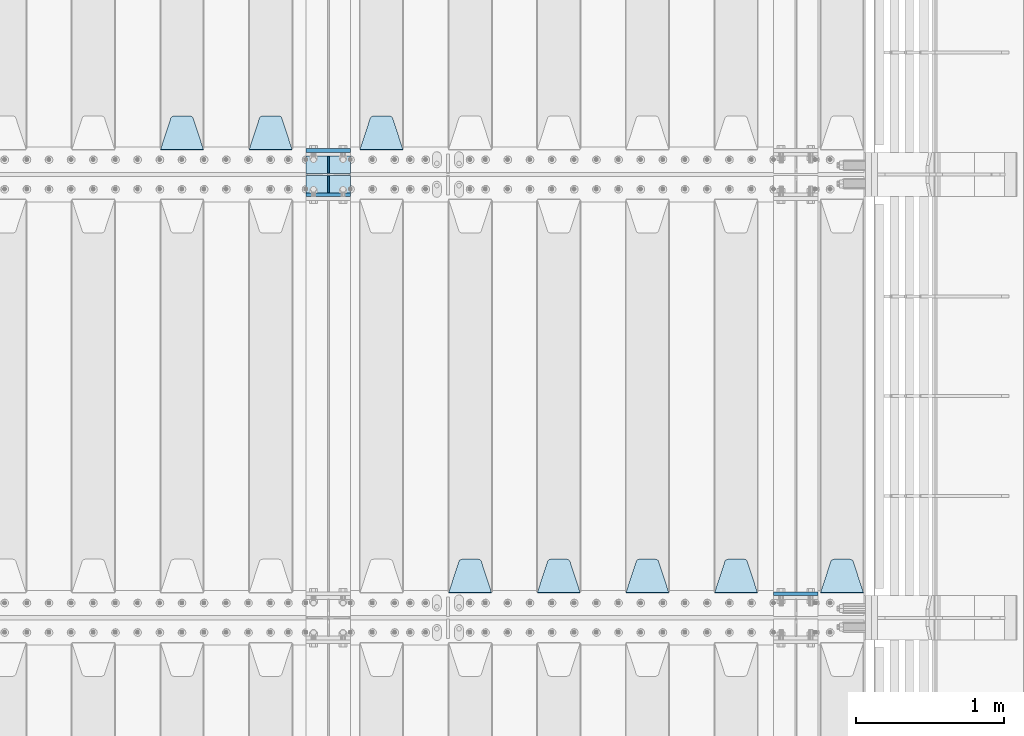
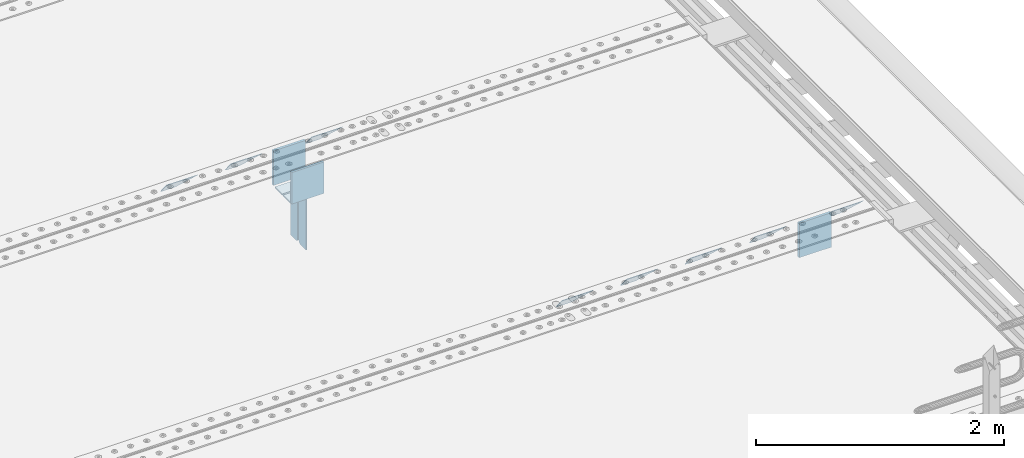
# One storey, part 206 of 240: 15 plates.
"""IFC2X3 building model written with IfcOpenShell, lengths in millimetres."""

import ifcopenshell
import ifcopenshell.guid

model = None  # the IFC model being written
_history = None  # IfcOwnerHistory: only IFC2X3 demands one
_inside = {}  # id of a spatial element -> (the spatial element, [elements in it])
_under = {}  # id of a project, library or spatial element -> (it, [spatial elements below it])
_declared = {}  # id of a project -> (the project, [libraries it declares])
_typed = {}  # id of a type object -> (the type object, [elements of that type])
_made_of = {}  # id of a material, layer set ... -> (it, [elements and type objects made of it])


def new_model(schema):
    """Start an empty IFC model of exactly this schema.

    Asked for "IFC4X3", IfcOpenShell would pick the latest addendum, in which some entities
    have other attributes; the version numbers below select the first issue.
    IFC2X3 requires an IfcOwnerHistory on every rooted entity: one is made here for all.
    """
    global model, _history
    if schema == "IFC4X3":
        model = ifcopenshell.file(schema_version=(4, 3, 0, 0))
    else:
        model = ifcopenshell.file(schema=schema)
    _inside.clear()
    _under.clear()
    _declared.clear()
    _typed.clear()
    _made_of.clear()
    _history = None
    if model.schema == "IFC2X3":
        org = make("IfcOrganization", Name="unknown")
        user = make(
            "IfcPersonAndOrganization",
            ThePerson=make("IfcPerson", FamilyName="unknown"),
            TheOrganization=org,
        )
        app = make(
            "IfcApplication",
            ApplicationDeveloper=org,
            Version="unknown",
            ApplicationFullName="unknown",
            ApplicationIdentifier="unknown",
        )
        _history = make(
            "IfcOwnerHistory",
            OwningUser=user,
            OwningApplication=app,
            ChangeAction="ADDED",
            CreationDate=0,
        )
    return model


def make(cls, **values):
    """One entity of the class cls with the attributes given. An attribute that is None is left unset."""
    return model.create_entity(
        cls, **{name: value for name, value in values.items() if value is not None}
    )


def rooted(cls, **values):
    """An entity with a GlobalId (a new one), such as an element, a storey or a relation."""
    return make(cls, GlobalId=ifcopenshell.guid.new(), OwnerHistory=_history, **values)


def si_unit(unit_type, name, prefix=None):
    """IfcSIUnit, for example si_unit("LENGTHUNIT", "METRE", prefix="MILLI")."""
    return make("IfcSIUnit", UnitType=unit_type, Prefix=prefix, Name=name)


def assignment(units):
    """IfcUnitAssignment: the units of a project."""
    return None if units is None else make("IfcUnitAssignment", Units=units)


def point(xyz):
    """IfcCartesianPoint."""
    return None if xyz is None else make("IfcCartesianPoint", Coordinates=xyz)


def direction(xyz):
    """IfcDirection."""
    return None if xyz is None else make("IfcDirection", DirectionRatios=xyz)


def frame(location, z_axis=None, x_axis=None):
    """IfcAxis2Placement3D, a coordinate frame: its origin and axes. An axis left out is left unset."""
    return make(
        "IfcAxis2Placement3D",
        Location=point(location),
        Axis=direction(z_axis),
        RefDirection=direction(x_axis),
    )


def origin_with_axes():
    """The frame at (0, 0, 0) with the z axis (0, 0, 1) and the x axis (1, 0, 0) written out."""
    return frame((0.0, 0.0, 0.0), z_axis=(0.0, 0.0, 1.0), x_axis=(1.0, 0.0, 0.0))


def place(relative_to, where):
    """IfcLocalPlacement: puts the frame where relative to a parent placement (None: the world)."""
    return make(
        "IfcLocalPlacement", PlacementRelTo=relative_to, RelativePlacement=where
    )


def context(
    kind, dimensions, precision=None, world=None, true_north=None, identifier=None
):
    """IfcGeometricRepresentationContext, for example the 3D "Model" context."""
    return make(
        "IfcGeometricRepresentationContext",
        ContextIdentifier=identifier,
        ContextType=kind,
        CoordinateSpaceDimension=dimensions,
        Precision=precision,
        WorldCoordinateSystem=world,
        TrueNorth=true_north,
    )


def subcontext(parent, identifier, kind, view, scale=None):
    """IfcGeometricRepresentationSubContext, for example "Body" below "Model"."""
    return make(
        "IfcGeometricRepresentationSubContext",
        ContextIdentifier=identifier,
        ContextType=kind,
        ParentContext=parent,
        TargetScale=scale,
        TargetView=view,
    )


def project(units=None, contexts=None):
    """IfcProject with its units and contexts."""
    return rooted(
        "IfcProject",
        Name="project",
        RepresentationContexts=contexts,
        UnitsInContext=assignment(units),
    )


def spatial(cls, under=None, at=None, **own):
    """A site, building, storey or space (cls), placed at a placement, below another one or the project."""
    s = rooted(cls, ObjectPlacement=at, **own)
    if under is not None:
        _under.setdefault(under.id(), (under, []))[1].append(s)
    return s


def faces_of(points, faces, orient=None, outer=None):
    """IfcFace entities. A face is a list of loops; a loop is a list of indices into points, from 0.

    orient and outer hold one flag for each loop. By default every Orientation is true, the
    first loop of a face is its IfcFaceOuterBound and the others are IfcFaceBound.
    """
    made = []
    for i, loops in enumerate(faces):
        bounds = []
        for j, loop in enumerate(loops):
            is_outer = j == 0 if outer is None else outer[i][j]
            bounds.append(
                make(
                    "IfcFaceOuterBound" if is_outer else "IfcFaceBound",
                    Bound=make("IfcPolyLoop", Polygon=[points[k] for k in loop]),
                    Orientation=True if orient is None else orient[i][j],
                )
            )
        made.append(make("IfcFace", Bounds=bounds))
    return made


def faceted_brep(points, faces, orient=None, outer=None, voids=None):
    """IfcFacetedBrep: a solid bounded by flat faces; with voids (closed shells), ...WithVoids."""
    shared = [point(p) for p in points]
    hull = make("IfcClosedShell", CfsFaces=faces_of(shared, faces, orient, outer))
    if voids is None:
        return make("IfcFacetedBrep", Outer=hull)
    return make(
        "IfcFacetedBrepWithVoids",
        Outer=hull,
        Voids=[
            make(cls, CfsFaces=faces_of(shared, fs, o, b)) for cls, fs, o, b in voids
        ],
    )


def shape(context_of_items, identifier, shape_type, items):
    """IfcShapeRepresentation: the items that make up one representation, for example the "Body"."""
    return make(
        "IfcShapeRepresentation",
        ContextOfItems=context_of_items,
        RepresentationIdentifier=identifier,
        RepresentationType=shape_type,
        Items=items,
    )


def material(Name=None, Category=None):
    """IfcMaterial."""
    return make("IfcMaterial", Name=Name, Category=Category)


def made_of(thing, what):
    """Note that an element or type object is made of a material, layer set ...; save() writes the relation."""
    if what is not None:
        _made_of.setdefault(what.id(), (what, []))[1].append(thing)
    return thing


def type_object(cls, material=None, **own):
    """A type object (cls), such as IfcWallType, which elements share."""
    return made_of(rooted(cls, **own), material)


def element(
    cls,
    number,
    at=None,
    inside=None,
    cuts=None,
    type_object=None,
    material=None,
    context=None,
    identifier="Body",
    shape_type=None,
    held_by="IfcProductDefinitionShape",
    body=None,
    shapes=None,
    **own,
):
    """One element of the class cls, such as IfcWall. Its Tag is "e" and its number.

    at: its placement. inside: the storey or other place that contains it. cuts: it is an
    opening in that element (IfcRelVoidsElement). A single representation is given by context,
    identifier, shape_type and body (its items); several are given by shapes. held_by: the class
    of the entity that holds the representations. save() writes the other relations.
    """
    e = rooted(cls, Tag="e%d" % number, ObjectPlacement=at, **own)
    if body is not None:
        shapes = [shape(context, identifier, shape_type, body)]
    if shapes is not None:
        e.Representation = make(held_by, Representations=shapes)
    if inside is not None:
        _inside.setdefault(inside.id(), (inside, []))[1].append(e)
    if cuts is not None:
        rooted(
            "IfcRelVoidsElement", RelatingBuildingElement=cuts, RelatedOpeningElement=e
        )
    if type_object is not None:
        _typed.setdefault(type_object.id(), (type_object, []))[1].append(e)
    return made_of(e, material)


def aggregate(whole, parts):
    """IfcRelAggregates: a whole, such as a stair, and the parts it consists of."""
    return rooted("IfcRelAggregates", RelatingObject=whole, RelatedObjects=parts)


def save(model, path):
    """Write the relations noted so far, then the file.

    IfcRelAggregates (storeys below a building ...), IfcRelContainedInSpatialStructure (elements
    in a storey), IfcRelDefinesByType, IfcRelAssociatesMaterial and IfcRelDeclares: one each for
    every whole, place, type object, material and project.
    """
    for whole, parts in _under.values():
        aggregate(whole, parts)
    for where, things in _inside.values():
        rooted(
            "IfcRelContainedInSpatialStructure",
            RelatedElements=things,
            RelatingStructure=where,
        )
    for kind, things in _typed.values():
        rooted("IfcRelDefinesByType", RelatedObjects=things, RelatingType=kind)
    for what, things in _made_of.values():
        rooted("IfcRelAssociatesMaterial", RelatedObjects=things, RelatingMaterial=what)
    for by, libraries in _declared.values():
        rooted("IfcRelDeclares", RelatingContext=by, RelatedDefinitions=libraries)
    model.write(path)


model = new_model("IFC2X3")

# Units and contexts
model_context = context("Model", 3, precision=1e-05, world=origin_with_axes())
body_context = subcontext(model_context, "Body", "Model", "MODEL_VIEW")
ifc_project = project(units=[si_unit("LENGTHUNIT", "METRE", prefix="MILLI"), si_unit("AREAUNIT", "SQUARE_METRE"), si_unit("VOLUMEUNIT", "CUBIC_METRE"), si_unit("MASSUNIT", "GRAM", prefix="KILO"), si_unit("TIMEUNIT", "SECOND"), si_unit("PLANEANGLEUNIT", "RADIAN"), si_unit("SOLIDANGLEUNIT", "STERADIAN"), si_unit("THERMODYNAMICTEMPERATUREUNIT", "DEGREE_CELSIUS"), si_unit("LUMINOUSINTENSITYUNIT", "LUMEN")], contexts=[model_context])

# Site, building, storey
site_placement = place(None, origin_with_axes())
site = spatial("IfcSite", under=ifc_project, at=site_placement, CompositionType="ELEMENT")
building_placement = place(site_placement, origin_with_axes())
building = spatial("IfcBuilding", under=site, at=building_placement, Name="Standard", CompositionType="ELEMENT")
storey_placement = place(building_placement, origin_with_axes())
storey = spatial("IfcBuildingStorey", under=building, at=storey_placement, Name="Undefined", CompositionType="ELEMENT", Elevation=0.0)

# Plates
ifc_material = material(Name="STEEL/S355N")
plate_type_1 = type_object("IfcPlateType", PredefinedType="NOTDEFINED")
for number, where, z_axis, x_axis in (
    (1, (55855.0, 27162.5, -340.000000000044), (0.0, 0.0, 1.0), (1.0, 0.0, 0.0)),
    (2, (52690.0, 30162.5, -340.000000000044), (0.0, 0.0, 1.0), (1.0, 0.0, 0.0)),
):
    element("IfcPlate", number, at=place(storey_placement, frame(where, z_axis=z_axis, x_axis=x_axis)), inside=storey, type_object=plate_type_1, material=ifc_material, context=body_context, shape_type="Brep", body=[
        faceted_brep([(0.0, -12.5, 0.0), (9.31322574615479e-10, -12.5, 340.0), (9.31322574615479e-10, 12.5, 340.0), (0.0, 12.5, 0.0), (300.0, -12.5, 340.0), (300.0, 12.5, 340.0), (300.0, -12.5, 0.0), (300.0, 12.5, 0.0)], [[[0, 1, 2, 3]], [[1, 4, 5, 2]], [[4, 6, 7, 5]], [[6, 0, 3, 7]], [[5, 7, 3, 2]], [[6, 4, 1, 0]]]),
    ])
plate_1_placement = place(storey_placement, frame((52690.0, 29862.5, -340.0), z_axis=(0.0, 0.0, 1.0), x_axis=(1.0, 0.0, 0.0)))
element("IfcPlate", 3, at=plate_1_placement, inside=storey, type_object=plate_type_1, material=ifc_material, context=body_context, shape_type="Brep", body=[
    faceted_brep([(0.0, -12.5, 0.0), (0.0, -12.5, 310.0), (0.0, 12.5, 310.0), (0.0, 12.5, 0.0), (300.0, -12.5, 310.0), (300.0, 12.5, 310.0), (300.0, -12.5, 0.0), (300.0, 12.5, 0.0)], [[[0, 1, 2, 3]], [[1, 4, 5, 2]], [[4, 6, 7, 5]], [[6, 0, 3, 7]], [[5, 7, 3, 2]], [[6, 4, 1, 0]]]),
])
plate_type_2 = type_object("IfcPlateType", PredefinedType="NOTDEFINED")
for number, where, z_axis, x_axis in (
    (4, (52690.0, 29992.0, -343.0), (0.0, -1.0, 0.0), (1.0, 0.0, 0.0)),
    (5, (52690.0, 30008.0, -343.0), (0.0, 1.0, 0.0), (1.0, 0.0, 0.0)),
):
    element("IfcPlate", number, at=place(storey_placement, frame(where, z_axis=z_axis, x_axis=x_axis)), inside=storey, type_object=plate_type_2, material=ifc_material, context=body_context, shape_type="Brep", body=[
        faceted_brep([(0.0, -7.0, 0.0), (0.0, -7.0, 117.0), (0.0, 7.0, 117.0), (0.0, 7.0, 0.0), (300.0, -7.0, 117.0), (300.0, 7.0, 117.0), (300.0, -7.0, 0.0), (300.0, 7.0, 0.0)], [[[0, 1, 2, 3]], [[1, 4, 5, 2]], [[4, 6, 7, 5]], [[6, 0, 3, 7]], [[5, 7, 3, 2]], [[6, 4, 1, 0]]]),
    ])
plate_type_3 = type_object("IfcPlateType", PredefinedType="NOTDEFINED")
for number, where, z_axis, x_axis in (
    (6, (52840.0, 29992.0, -350.0), (0.0, 0.0, -1.0), (0.0, -1.0, 0.0)),
    (7, (52840.0, 30008.0, -350.0), (0.0, 0.0, -1.0), (0.0, 1.0, 0.0)),
):
    element("IfcPlate", number, at=place(storey_placement, frame(where, z_axis=z_axis, x_axis=x_axis)), inside=storey, type_object=plate_type_3, material=ifc_material, context=body_context, shape_type="Brep", body=[
        faceted_brep([(0.0, -5.0, 0.0), (0.0, -5.0, 480.0), (0.0, 5.0, 480.0), (0.0, 5.0, 0.0), (0.455767409635882, -5.0, 485.209445330008), (0.455767409635882, 5.0, 485.209445330008), (1.80922137642483, -5.0, 490.26060429977), (1.80922137642483, 5.0, 490.26060429977), (4.01923788646673, -5.0, 495.0), (4.01923788646673, 5.0, 495.0), (7.01866670643358, -5.0, 499.283628290596), (7.01866670643358, 5.0, 499.283628290596), (10.7163717094008, -5.0, 502.981333293569), (10.7163717094008, 5.0, 502.981333293569), (15.0, -5.0, 505.980762113533), (15.0, 5.0, 505.980762113533), (19.7393957002278, -5.0, 508.190778623577), (19.7393957002278, 5.0, 508.190778623577), (24.7905546699913, -5.0, 509.544232590366), (24.7905546699913, 5.0, 509.544232590366), (30.0, -5.0, 510.0), (30.0, 5.0, 510.0), (117.0, -5.0, 510.0), (117.0, 5.0, 510.0), (117.0, -5.0, 0.0), (117.0, 5.0, 0.0)], [[[0, 1, 2, 3]], [[1, 4, 5, 2]], [[4, 6, 7, 5]], [[6, 8, 9, 7]], [[8, 10, 11, 9]], [[10, 12, 13, 11]], [[12, 14, 15, 13]], [[14, 16, 17, 15]], [[16, 18, 19, 17]], [[18, 20, 21, 19]], [[20, 22, 23, 21]], [[22, 24, 25, 23]], [[24, 0, 3, 25]], [[5, 7, 9, 11, 13, 15, 17, 19, 21, 23, 25, 3, 2]], [[24, 22, 20, 18, 16, 14, 12, 10, 8, 6, 4, 1, 0]]]),
    ])
plate_type_4 = type_object("IfcPlateType", PredefinedType="NOTDEFINED")
plate_2_placement = place(storey_placement, frame((53345.0, 30168.232233047, -1.76776695296758), z_axis=(0.0, 0.707106781186547, -0.707106781186548), x_axis=(-1.0, 0.0, 0.0)))
element("IfcPlate", 8, at=plate_2_placement, inside=storey, type_object=plate_type_4, material=ifc_material, context=body_context, shape_type="Brep", body=[
    faceted_brep([(0.0, -2.5, 0.0), (69.345504679477, -2.50000000000364, 300.171731424827), (69.345504679477, 2.49999999999636, 300.171731424827), (0.0, 2.5, 0.0), (70.927406119954, -2.50000000000364, 304.897442415397), (70.927406119954, 2.49999999999636, 304.897442415397), (73.3818627772271, -2.50000000000728, 309.234538108525), (73.3818627772271, 2.49999999999636, 309.234538108529), (76.6187032999587, -2.50000000000728, 313.023683126099), (76.6187032999587, 2.49999999999636, 313.023683126103), (80.5190132705029, -2.50000000000364, 316.125672595368), (80.5190132705029, 2.49999999999636, 316.125672595368), (84.9395038596849, -2.50000000000364, 318.426546230472), (84.9395038596849, 2.49999999999636, 318.426546230472), (89.7177759439219, -2.5, 319.841774983277), (89.7177759439219, 2.49999999999636, 319.841774983273), (94.6782862926484, -2.50000000000364, 320.319366455074), (94.6782862926484, 2.49999999999636, 320.319366455074), (195.321713707352, -2.50000000000364, 320.319366455074), (195.321713707352, 2.49999999999636, 320.319366455074), (200.282224056078, -2.50000000000364, 319.841774983273), (200.282224056078, 2.49999999999636, 319.841774983273), (205.060496140315, -2.50000000000364, 318.426546230472), (205.060496140315, 2.49999999999636, 318.426546230472), (209.480986729497, -2.50000000000364, 316.125672595368), (209.480986729497, 2.49999999999636, 316.125672595368), (213.381296700041, -2.50000000000728, 313.023683126099), (213.381296700041, 2.49999999999272, 313.023683126099), (216.618137222766, -2.50000000000364, 309.234538108522), (216.618137222766, 2.49999999999636, 309.234538108522), (219.072593880039, -2.50000000000364, 304.897442415397), (219.072593880039, 2.49999999999636, 304.897442415397), (220.654495320523, -2.50000000000364, 300.171731424827), (220.654495320523, 2.49999999999636, 300.171731424827), (290.0, -2.50000000000364, -3.63797880709171e-12), (290.0, 2.49999999999636, -3.63797880709171e-12)], [[[0, 1, 2, 3]], [[1, 4, 5, 2]], [[4, 6, 7, 5]], [[6, 8, 9, 7]], [[8, 10, 11, 9]], [[10, 12, 13, 11]], [[12, 14, 15, 13]], [[14, 16, 17, 15]], [[16, 18, 19, 17]], [[18, 20, 21, 19]], [[20, 22, 23, 21]], [[22, 24, 25, 23]], [[24, 26, 27, 25]], [[26, 28, 29, 27]], [[28, 30, 31, 29]], [[30, 32, 33, 31]], [[32, 34, 35, 33]], [[34, 0, 3, 35]], [[5, 7, 9, 11, 13, 15, 17, 19, 21, 23, 25, 27, 29, 31, 33, 35, 3, 2]], [[34, 32, 30, 28, 26, 24, 22, 20, 18, 16, 14, 12, 10, 8, 6, 4, 1, 0]]]),
])
plate_3_placement = place(storey_placement, frame((52595.0, 30168.232233047, -1.76776695296758), z_axis=(0.0, 0.707106781186547, -0.707106781186548), x_axis=(-1.0, 0.0, 0.0)))
element("IfcPlate", 9, at=plate_3_placement, inside=storey, type_object=plate_type_4, material=ifc_material, context=body_context, shape_type="Brep", body=[
    faceted_brep([(0.0, -2.5, 0.0), (69.345504679477, -2.50000000000364, 300.171731424827), (69.345504679477, 2.49999999999636, 300.171731424827), (0.0, 2.5, 0.0), (70.927406119954, -2.50000000000364, 304.897442415397), (70.927406119954, 2.49999999999636, 304.897442415397), (73.3818627772271, -2.50000000000728, 309.234538108525), (73.3818627772271, 2.49999999999636, 309.234538108529), (76.6187032999587, -2.50000000000728, 313.023683126099), (76.6187032999587, 2.49999999999636, 313.023683126103), (80.5190132705029, -2.50000000000364, 316.125672595368), (80.5190132705029, 2.49999999999636, 316.125672595368), (84.9395038596849, -2.50000000000364, 318.426546230472), (84.9395038596849, 2.49999999999636, 318.426546230472), (89.7177759439219, -2.5, 319.841774983277), (89.7177759439219, 2.49999999999636, 319.841774983273), (94.6782862926484, -2.50000000000364, 320.319366455074), (94.6782862926484, 2.49999999999636, 320.319366455074), (195.321713707352, -2.50000000000364, 320.319366455074), (195.321713707352, 2.49999999999636, 320.319366455074), (200.282224056078, -2.50000000000364, 319.841774983273), (200.282224056078, 2.49999999999636, 319.841774983273), (205.060496140315, -2.50000000000364, 318.426546230472), (205.060496140315, 2.49999999999636, 318.426546230472), (209.480986729497, -2.50000000000364, 316.125672595368), (209.480986729497, 2.49999999999636, 316.125672595368), (213.381296700041, -2.50000000000728, 313.023683126099), (213.381296700041, 2.49999999999272, 313.023683126099), (216.618137222766, -2.50000000000364, 309.234538108522), (216.618137222766, 2.49999999999636, 309.234538108522), (219.072593880039, -2.50000000000364, 304.897442415397), (219.072593880039, 2.49999999999636, 304.897442415397), (220.654495320523, -2.50000000000364, 300.171731424827), (220.654495320523, 2.49999999999636, 300.171731424827), (290.0, -2.50000000000364, -3.63797880709171e-12), (290.0, 2.49999999999636, -3.63797880709171e-12)], [[[0, 1, 2, 3]], [[1, 4, 5, 2]], [[4, 6, 7, 5]], [[6, 8, 9, 7]], [[8, 10, 11, 9]], [[10, 12, 13, 11]], [[12, 14, 15, 13]], [[14, 16, 17, 15]], [[16, 18, 19, 17]], [[18, 20, 21, 19]], [[20, 22, 23, 21]], [[22, 24, 25, 23]], [[24, 26, 27, 25]], [[26, 28, 29, 27]], [[28, 30, 31, 29]], [[30, 32, 33, 31]], [[32, 34, 35, 33]], [[34, 0, 3, 35]], [[5, 7, 9, 11, 13, 15, 17, 19, 21, 23, 25, 27, 29, 31, 33, 35, 3, 2]], [[34, 32, 30, 28, 26, 24, 22, 20, 18, 16, 14, 12, 10, 8, 6, 4, 1, 0]]]),
])
plate_4_placement = place(storey_placement, frame((51995.0, 30168.232233047, -1.76776695296758), z_axis=(0.0, 0.707106781186547, -0.707106781186548), x_axis=(-1.0, 0.0, 0.0)))
element("IfcPlate", 10, at=plate_4_placement, inside=storey, type_object=plate_type_4, material=ifc_material, context=body_context, shape_type="Brep", body=[
    faceted_brep([(0.0, -2.5, 0.0), (69.345504679477, -2.50000000000364, 300.171731424827), (69.345504679477, 2.49999999999636, 300.171731424827), (0.0, 2.5, 0.0), (70.927406119954, -2.50000000000364, 304.897442415397), (70.927406119954, 2.49999999999636, 304.897442415397), (73.3818627772271, -2.50000000000728, 309.234538108525), (73.3818627772271, 2.49999999999636, 309.234538108529), (76.6187032999587, -2.50000000000728, 313.023683126099), (76.6187032999587, 2.49999999999636, 313.023683126103), (80.5190132705029, -2.50000000000364, 316.125672595368), (80.5190132705029, 2.49999999999636, 316.125672595368), (84.9395038596849, -2.50000000000364, 318.426546230472), (84.9395038596849, 2.49999999999636, 318.426546230472), (89.7177759439219, -2.5, 319.841774983277), (89.7177759439219, 2.49999999999636, 319.841774983273), (94.6782862926484, -2.50000000000364, 320.319366455074), (94.6782862926484, 2.49999999999636, 320.319366455074), (195.321713707352, -2.50000000000364, 320.319366455074), (195.321713707352, 2.49999999999636, 320.319366455074), (200.282224056078, -2.50000000000364, 319.841774983273), (200.282224056078, 2.49999999999636, 319.841774983273), (205.060496140315, -2.50000000000364, 318.426546230472), (205.060496140315, 2.49999999999636, 318.426546230472), (209.480986729497, -2.50000000000364, 316.125672595368), (209.480986729497, 2.49999999999636, 316.125672595368), (213.381296700041, -2.50000000000728, 313.023683126099), (213.381296700041, 2.49999999999272, 313.023683126099), (216.618137222766, -2.50000000000364, 309.234538108522), (216.618137222766, 2.49999999999636, 309.234538108522), (219.072593880039, -2.50000000000364, 304.897442415397), (219.072593880039, 2.49999999999636, 304.897442415397), (220.654495320523, -2.50000000000364, 300.171731424827), (220.654495320523, 2.49999999999636, 300.171731424827), (290.0, -2.50000000000364, -3.63797880709171e-12), (290.0, 2.49999999999636, -3.63797880709171e-12)], [[[0, 1, 2, 3]], [[1, 4, 5, 2]], [[4, 6, 7, 5]], [[6, 8, 9, 7]], [[8, 10, 11, 9]], [[10, 12, 13, 11]], [[12, 14, 15, 13]], [[14, 16, 17, 15]], [[16, 18, 19, 17]], [[18, 20, 21, 19]], [[20, 22, 23, 21]], [[22, 24, 25, 23]], [[24, 26, 27, 25]], [[26, 28, 29, 27]], [[28, 30, 31, 29]], [[30, 32, 33, 31]], [[32, 34, 35, 33]], [[34, 0, 3, 35]], [[5, 7, 9, 11, 13, 15, 17, 19, 21, 23, 25, 27, 29, 31, 33, 35, 3, 2]], [[34, 32, 30, 28, 26, 24, 22, 20, 18, 16, 14, 12, 10, 8, 6, 4, 1, 0]]]),
])
plate_5_placement = place(storey_placement, frame((56462.0, 27168.232233047, -1.76776695296758), z_axis=(0.0, 0.707106781186547, -0.707106781186548), x_axis=(-1.0, 0.0, 0.0)))
element("IfcPlate", 11, at=plate_5_placement, inside=storey, type_object=plate_type_4, material=ifc_material, context=body_context, shape_type="Brep", body=[
    faceted_brep([(0.0, -2.5, 0.0), (69.345504679477, -2.50000000000364, 300.171731424827), (69.345504679477, 2.49999999999636, 300.171731424827), (0.0, 2.5, 0.0), (70.927406119954, -2.50000000000364, 304.897442415397), (70.927406119954, 2.49999999999636, 304.897442415397), (73.3818627772271, -2.50000000000728, 309.234538108525), (73.3818627772271, 2.49999999999636, 309.234538108529), (76.6187032999587, -2.50000000000728, 313.023683126099), (76.6187032999587, 2.49999999999636, 313.023683126103), (80.5190132705029, -2.50000000000364, 316.125672595368), (80.5190132705029, 2.49999999999636, 316.125672595368), (84.9395038596849, -2.50000000000364, 318.426546230472), (84.9395038596849, 2.49999999999636, 318.426546230472), (89.7177759439219, -2.5, 319.841774983277), (89.7177759439219, 2.49999999999636, 319.841774983273), (94.6782862926484, -2.50000000000364, 320.319366455074), (94.6782862926484, 2.49999999999636, 320.319366455074), (195.321713707352, -2.50000000000364, 320.319366455074), (195.321713707352, 2.49999999999636, 320.319366455074), (200.282224056078, -2.50000000000364, 319.841774983273), (200.282224056078, 2.49999999999636, 319.841774983273), (205.060496140315, -2.50000000000364, 318.426546230472), (205.060496140315, 2.49999999999636, 318.426546230472), (209.480986729497, -2.50000000000364, 316.125672595368), (209.480986729497, 2.49999999999636, 316.125672595368), (213.381296700041, -2.50000000000728, 313.023683126099), (213.381296700041, 2.49999999999272, 313.023683126099), (216.618137222766, -2.50000000000364, 309.234538108522), (216.618137222766, 2.49999999999636, 309.234538108522), (219.072593880039, -2.50000000000364, 304.897442415397), (219.072593880039, 2.49999999999636, 304.897442415397), (220.654495320523, -2.50000000000364, 300.171731424827), (220.654495320523, 2.49999999999636, 300.171731424827), (290.0, -2.50000000000364, -3.63797880709171e-12), (290.0, 2.49999999999636, -3.63797880709171e-12)], [[[0, 1, 2, 3]], [[1, 4, 5, 2]], [[4, 6, 7, 5]], [[6, 8, 9, 7]], [[8, 10, 11, 9]], [[10, 12, 13, 11]], [[12, 14, 15, 13]], [[14, 16, 17, 15]], [[16, 18, 19, 17]], [[18, 20, 21, 19]], [[20, 22, 23, 21]], [[22, 24, 25, 23]], [[24, 26, 27, 25]], [[26, 28, 29, 27]], [[28, 30, 31, 29]], [[30, 32, 33, 31]], [[32, 34, 35, 33]], [[34, 0, 3, 35]], [[5, 7, 9, 11, 13, 15, 17, 19, 21, 23, 25, 27, 29, 31, 33, 35, 3, 2]], [[34, 32, 30, 28, 26, 24, 22, 20, 18, 16, 14, 12, 10, 8, 6, 4, 1, 0]]]),
])
plate_6_placement = place(storey_placement, frame((55745.0, 27168.232233047, -1.76776695296758), z_axis=(0.0, 0.707106781186547, -0.707106781186548), x_axis=(-1.0, 0.0, 0.0)))
element("IfcPlate", 12, at=plate_6_placement, inside=storey, type_object=plate_type_4, material=ifc_material, context=body_context, shape_type="Brep", body=[
    faceted_brep([(0.0, -2.5, 0.0), (69.345504679477, -2.50000000000364, 300.171731424827), (69.345504679477, 2.49999999999636, 300.171731424827), (0.0, 2.5, 0.0), (70.927406119954, -2.50000000000364, 304.897442415397), (70.927406119954, 2.49999999999636, 304.897442415397), (73.3818627772271, -2.50000000000728, 309.234538108525), (73.3818627772271, 2.49999999999636, 309.234538108529), (76.6187032999587, -2.50000000000728, 313.023683126099), (76.6187032999587, 2.49999999999636, 313.023683126103), (80.5190132705029, -2.50000000000364, 316.125672595368), (80.5190132705029, 2.49999999999636, 316.125672595368), (84.9395038596849, -2.50000000000364, 318.426546230472), (84.9395038596849, 2.49999999999636, 318.426546230472), (89.7177759439219, -2.5, 319.841774983277), (89.7177759439219, 2.49999999999636, 319.841774983273), (94.6782862926484, -2.50000000000364, 320.319366455074), (94.6782862926484, 2.49999999999636, 320.319366455074), (195.321713707352, -2.50000000000364, 320.319366455074), (195.321713707352, 2.49999999999636, 320.319366455074), (200.282224056078, -2.50000000000364, 319.841774983273), (200.282224056078, 2.49999999999636, 319.841774983273), (205.060496140315, -2.50000000000364, 318.426546230472), (205.060496140315, 2.49999999999636, 318.426546230472), (209.480986729497, -2.50000000000364, 316.125672595368), (209.480986729497, 2.49999999999636, 316.125672595368), (213.381296700041, -2.50000000000728, 313.023683126099), (213.381296700041, 2.49999999999272, 313.023683126099), (216.618137222766, -2.50000000000364, 309.234538108522), (216.618137222766, 2.49999999999636, 309.234538108522), (219.072593880039, -2.50000000000364, 304.897442415397), (219.072593880039, 2.49999999999636, 304.897442415397), (220.654495320523, -2.50000000000364, 300.171731424827), (220.654495320523, 2.49999999999636, 300.171731424827), (290.0, -2.50000000000364, -3.63797880709171e-12), (290.0, 2.49999999999636, -3.63797880709171e-12)], [[[0, 1, 2, 3]], [[1, 4, 5, 2]], [[4, 6, 7, 5]], [[6, 8, 9, 7]], [[8, 10, 11, 9]], [[10, 12, 13, 11]], [[12, 14, 15, 13]], [[14, 16, 17, 15]], [[16, 18, 19, 17]], [[18, 20, 21, 19]], [[20, 22, 23, 21]], [[22, 24, 25, 23]], [[24, 26, 27, 25]], [[26, 28, 29, 27]], [[28, 30, 31, 29]], [[30, 32, 33, 31]], [[32, 34, 35, 33]], [[34, 0, 3, 35]], [[5, 7, 9, 11, 13, 15, 17, 19, 21, 23, 25, 27, 29, 31, 33, 35, 3, 2]], [[34, 32, 30, 28, 26, 24, 22, 20, 18, 16, 14, 12, 10, 8, 6, 4, 1, 0]]]),
])
plate_7_placement = place(storey_placement, frame((55145.0, 27168.232233047, -1.76776695296758), z_axis=(0.0, 0.707106781186547, -0.707106781186548), x_axis=(-1.0, 0.0, 0.0)))
element("IfcPlate", 13, at=plate_7_placement, inside=storey, type_object=plate_type_4, material=ifc_material, context=body_context, shape_type="Brep", body=[
    faceted_brep([(0.0, -2.5, 0.0), (69.345504679477, -2.50000000000364, 300.171731424827), (69.345504679477, 2.49999999999636, 300.171731424827), (0.0, 2.5, 0.0), (70.927406119954, -2.50000000000364, 304.897442415397), (70.927406119954, 2.49999999999636, 304.897442415397), (73.3818627772271, -2.50000000000728, 309.234538108525), (73.3818627772271, 2.49999999999636, 309.234538108529), (76.6187032999587, -2.50000000000728, 313.023683126099), (76.6187032999587, 2.49999999999636, 313.023683126103), (80.5190132705029, -2.50000000000364, 316.125672595368), (80.5190132705029, 2.49999999999636, 316.125672595368), (84.9395038596849, -2.50000000000364, 318.426546230472), (84.9395038596849, 2.49999999999636, 318.426546230472), (89.7177759439219, -2.5, 319.841774983277), (89.7177759439219, 2.49999999999636, 319.841774983273), (94.6782862926484, -2.50000000000364, 320.319366455074), (94.6782862926484, 2.49999999999636, 320.319366455074), (195.321713707352, -2.50000000000364, 320.319366455074), (195.321713707352, 2.49999999999636, 320.319366455074), (200.282224056078, -2.50000000000364, 319.841774983273), (200.282224056078, 2.49999999999636, 319.841774983273), (205.060496140315, -2.50000000000364, 318.426546230472), (205.060496140315, 2.49999999999636, 318.426546230472), (209.480986729497, -2.50000000000364, 316.125672595368), (209.480986729497, 2.49999999999636, 316.125672595368), (213.381296700041, -2.50000000000728, 313.023683126099), (213.381296700041, 2.49999999999272, 313.023683126099), (216.618137222766, -2.50000000000364, 309.234538108522), (216.618137222766, 2.49999999999636, 309.234538108522), (219.072593880039, -2.50000000000364, 304.897442415397), (219.072593880039, 2.49999999999636, 304.897442415397), (220.654495320523, -2.50000000000364, 300.171731424827), (220.654495320523, 2.49999999999636, 300.171731424827), (290.0, -2.50000000000364, -3.63797880709171e-12), (290.0, 2.49999999999636, -3.63797880709171e-12)], [[[0, 1, 2, 3]], [[1, 4, 5, 2]], [[4, 6, 7, 5]], [[6, 8, 9, 7]], [[8, 10, 11, 9]], [[10, 12, 13, 11]], [[12, 14, 15, 13]], [[14, 16, 17, 15]], [[16, 18, 19, 17]], [[18, 20, 21, 19]], [[20, 22, 23, 21]], [[22, 24, 25, 23]], [[24, 26, 27, 25]], [[26, 28, 29, 27]], [[28, 30, 31, 29]], [[30, 32, 33, 31]], [[32, 34, 35, 33]], [[34, 0, 3, 35]], [[5, 7, 9, 11, 13, 15, 17, 19, 21, 23, 25, 27, 29, 31, 33, 35, 3, 2]], [[34, 32, 30, 28, 26, 24, 22, 20, 18, 16, 14, 12, 10, 8, 6, 4, 1, 0]]]),
])
plate_8_placement = place(storey_placement, frame((54545.0, 27168.232233047, -1.76776695296758), z_axis=(0.0, 0.707106781186547, -0.707106781186548), x_axis=(-1.0, 0.0, 0.0)))
element("IfcPlate", 14, at=plate_8_placement, inside=storey, type_object=plate_type_4, material=ifc_material, context=body_context, shape_type="Brep", body=[
    faceted_brep([(0.0, -2.5, 0.0), (69.345504679477, -2.50000000000364, 300.171731424827), (69.345504679477, 2.49999999999636, 300.171731424827), (0.0, 2.5, 0.0), (70.927406119954, -2.50000000000364, 304.897442415397), (70.927406119954, 2.49999999999636, 304.897442415397), (73.3818627772271, -2.50000000000728, 309.234538108525), (73.3818627772271, 2.49999999999636, 309.234538108529), (76.6187032999587, -2.50000000000728, 313.023683126099), (76.6187032999587, 2.49999999999636, 313.023683126103), (80.5190132705029, -2.50000000000364, 316.125672595368), (80.5190132705029, 2.49999999999636, 316.125672595368), (84.9395038596849, -2.50000000000364, 318.426546230472), (84.9395038596849, 2.49999999999636, 318.426546230472), (89.7177759439219, -2.5, 319.841774983277), (89.7177759439219, 2.49999999999636, 319.841774983273), (94.6782862926484, -2.50000000000364, 320.319366455074), (94.6782862926484, 2.49999999999636, 320.319366455074), (195.321713707352, -2.50000000000364, 320.319366455074), (195.321713707352, 2.49999999999636, 320.319366455074), (200.282224056078, -2.50000000000364, 319.841774983273), (200.282224056078, 2.49999999999636, 319.841774983273), (205.060496140315, -2.50000000000364, 318.426546230472), (205.060496140315, 2.49999999999636, 318.426546230472), (209.480986729497, -2.50000000000364, 316.125672595368), (209.480986729497, 2.49999999999636, 316.125672595368), (213.381296700041, -2.50000000000728, 313.023683126099), (213.381296700041, 2.49999999999272, 313.023683126099), (216.618137222766, -2.50000000000364, 309.234538108522), (216.618137222766, 2.49999999999636, 309.234538108522), (219.072593880039, -2.50000000000364, 304.897442415397), (219.072593880039, 2.49999999999636, 304.897442415397), (220.654495320523, -2.50000000000364, 300.171731424827), (220.654495320523, 2.49999999999636, 300.171731424827), (290.0, -2.50000000000364, -3.63797880709171e-12), (290.0, 2.49999999999636, -3.63797880709171e-12)], [[[0, 1, 2, 3]], [[1, 4, 5, 2]], [[4, 6, 7, 5]], [[6, 8, 9, 7]], [[8, 10, 11, 9]], [[10, 12, 13, 11]], [[12, 14, 15, 13]], [[14, 16, 17, 15]], [[16, 18, 19, 17]], [[18, 20, 21, 19]], [[20, 22, 23, 21]], [[22, 24, 25, 23]], [[24, 26, 27, 25]], [[26, 28, 29, 27]], [[28, 30, 31, 29]], [[30, 32, 33, 31]], [[32, 34, 35, 33]], [[34, 0, 3, 35]], [[5, 7, 9, 11, 13, 15, 17, 19, 21, 23, 25, 27, 29, 31, 33, 35, 3, 2]], [[34, 32, 30, 28, 26, 24, 22, 20, 18, 16, 14, 12, 10, 8, 6, 4, 1, 0]]]),
])
plate_9_placement = place(storey_placement, frame((53945.0, 27168.232233047, -1.76776695296758), z_axis=(0.0, 0.707106781186547, -0.707106781186548), x_axis=(-1.0, 0.0, 0.0)))
element("IfcPlate", 15, at=plate_9_placement, inside=storey, type_object=plate_type_4, material=ifc_material, context=body_context, shape_type="Brep", body=[
    faceted_brep([(0.0, -2.5, 0.0), (69.345504679477, -2.50000000000364, 300.171731424827), (69.345504679477, 2.49999999999636, 300.171731424827), (0.0, 2.5, 0.0), (70.927406119954, -2.50000000000364, 304.897442415397), (70.927406119954, 2.49999999999636, 304.897442415397), (73.3818627772271, -2.50000000000728, 309.234538108525), (73.3818627772271, 2.49999999999636, 309.234538108529), (76.6187032999587, -2.50000000000728, 313.023683126099), (76.6187032999587, 2.49999999999636, 313.023683126103), (80.5190132705029, -2.50000000000364, 316.125672595368), (80.5190132705029, 2.49999999999636, 316.125672595368), (84.9395038596849, -2.50000000000364, 318.426546230472), (84.9395038596849, 2.49999999999636, 318.426546230472), (89.7177759439219, -2.5, 319.841774983277), (89.7177759439219, 2.49999999999636, 319.841774983273), (94.6782862926484, -2.50000000000364, 320.319366455074), (94.6782862926484, 2.49999999999636, 320.319366455074), (195.321713707352, -2.50000000000364, 320.319366455074), (195.321713707352, 2.49999999999636, 320.319366455074), (200.282224056078, -2.50000000000364, 319.841774983273), (200.282224056078, 2.49999999999636, 319.841774983273), (205.060496140315, -2.50000000000364, 318.426546230472), (205.060496140315, 2.49999999999636, 318.426546230472), (209.480986729497, -2.50000000000364, 316.125672595368), (209.480986729497, 2.49999999999636, 316.125672595368), (213.381296700041, -2.50000000000728, 313.023683126099), (213.381296700041, 2.49999999999272, 313.023683126099), (216.618137222766, -2.50000000000364, 309.234538108522), (216.618137222766, 2.49999999999636, 309.234538108522), (219.072593880039, -2.50000000000364, 304.897442415397), (219.072593880039, 2.49999999999636, 304.897442415397), (220.654495320523, -2.50000000000364, 300.171731424827), (220.654495320523, 2.49999999999636, 300.171731424827), (290.0, -2.50000000000364, -3.63797880709171e-12), (290.0, 2.49999999999636, -3.63797880709171e-12)], [[[0, 1, 2, 3]], [[1, 4, 5, 2]], [[4, 6, 7, 5]], [[6, 8, 9, 7]], [[8, 10, 11, 9]], [[10, 12, 13, 11]], [[12, 14, 15, 13]], [[14, 16, 17, 15]], [[16, 18, 19, 17]], [[18, 20, 21, 19]], [[20, 22, 23, 21]], [[22, 24, 25, 23]], [[24, 26, 27, 25]], [[26, 28, 29, 27]], [[28, 30, 31, 29]], [[30, 32, 33, 31]], [[32, 34, 35, 33]], [[34, 0, 3, 35]], [[5, 7, 9, 11, 13, 15, 17, 19, 21, 23, 25, 27, 29, 31, 33, 35, 3, 2]], [[34, 32, 30, 28, 26, 24, 22, 20, 18, 16, 14, 12, 10, 8, 6, 4, 1, 0]]]),
])

save(model, "model.ifc")
